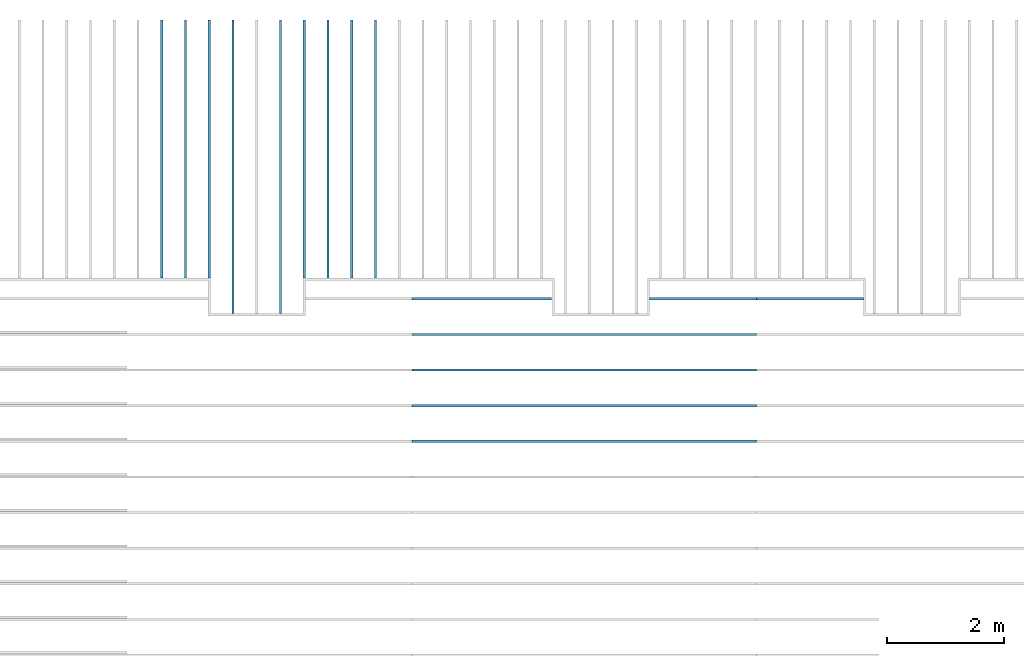
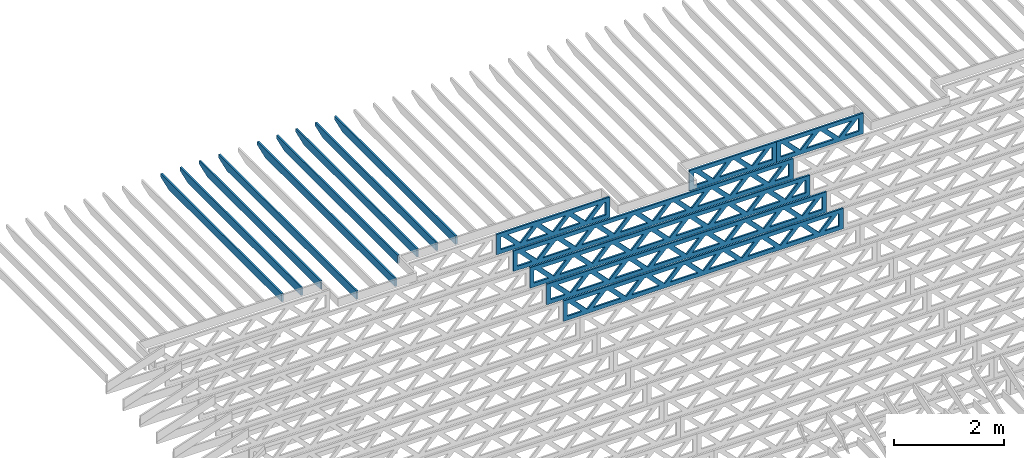
# One storey, part 5 of 17: 16 beams, 3 elements without a shape of their own.
"""IFC4 building model written with IfcOpenShell, lengths in feet."""

from ifc_helpers import new_model, entity, si_unit, converted_unit, derived_unit, direction, frame, frame_2d, origin, origin_2d_with_axis, place, context, subcontext, project, spatial, rectangle, extrude, clip, halfspace, source, transform, mapped, material, material_profile, profile_set, profile_usage, type_object, type_shapes, element, aggregate, save


model = new_model("IFC4")

# Units and contexts
model_context = context("Model", 3, precision=0.0001, world=origin(), true_north=direction((6.12303176911189e-17, 1.0)))
body_context = subcontext(model_context, "Body", "Model", "MODEL_VIEW")
ifc_project = project(units=[converted_unit("LENGTHUNIT", "FOOT", entity("IfcRatioMeasure", 0.3048), si_unit("LENGTHUNIT", "METRE"), dimensions=[1, 0, 0, 0, 0, 0, 0]), converted_unit("AREAUNIT", "SQUARE FOOT", entity("IfcRatioMeasure", 0.09290304), si_unit("AREAUNIT", "SQUARE_METRE"), dimensions=[2, 0, 0, 0, 0, 0, 0]), converted_unit("VOLUMEUNIT", "CUBIC FOOT", entity("IfcRatioMeasure", 0.028316846592), si_unit("VOLUMEUNIT", "CUBIC_METRE"), dimensions=[3, 0, 0, 0, 0, 0, 0]), converted_unit("PLANEANGLEUNIT", "DEGREE", entity("IfcRatioMeasure", 0.0174532925199433), si_unit("PLANEANGLEUNIT", "RADIAN"), dimensions=[0, 0, 0, 0, 0, 0, 0]), si_unit("MASSUNIT", "GRAM", prefix="KILO"), derived_unit("MASSDENSITYUNIT", [(si_unit("MASSUNIT", "GRAM", prefix="KILO"), 1), (si_unit("LENGTHUNIT", "METRE"), -3)]), derived_unit("MOMENTOFINERTIAUNIT", [(si_unit("LENGTHUNIT", "METRE"), 4)]), si_unit("TIMEUNIT", "SECOND"), si_unit("FREQUENCYUNIT", "HERTZ"), si_unit("THERMODYNAMICTEMPERATUREUNIT", "DEGREE_CELSIUS"), derived_unit("THERMALTRANSMITTANCEUNIT", [(si_unit("MASSUNIT", "GRAM", prefix="KILO"), 1), (si_unit("THERMODYNAMICTEMPERATUREUNIT", "KELVIN"), -1), (si_unit("TIMEUNIT", "SECOND"), -3)]), derived_unit("VOLUMETRICFLOWRATEUNIT", [(si_unit("LENGTHUNIT", "METRE"), 3), (si_unit("TIMEUNIT", "SECOND"), -1)]), si_unit("ELECTRICCURRENTUNIT", "AMPERE"), si_unit("ELECTRICVOLTAGEUNIT", "VOLT"), si_unit("POWERUNIT", "WATT"), si_unit("FORCEUNIT", "NEWTON"), si_unit("ILLUMINANCEUNIT", "LUX"), si_unit("LUMINOUSFLUXUNIT", "LUMEN"), si_unit("LUMINOUSINTENSITYUNIT", "CANDELA"), derived_unit("USERDEFINED", [(si_unit("MASSUNIT", "GRAM", prefix="KILO"), -1), (si_unit("LENGTHUNIT", "METRE"), -2), (si_unit("TIMEUNIT", "SECOND"), 3), (si_unit("LUMINOUSFLUXUNIT", "LUMEN"), 1)]), derived_unit("LINEARVELOCITYUNIT", [(si_unit("LENGTHUNIT", "METRE"), 1), (si_unit("TIMEUNIT", "SECOND"), -1)]), si_unit("PRESSUREUNIT", "PASCAL"), derived_unit("USERDEFINED", [(si_unit("LENGTHUNIT", "METRE"), -2), (si_unit("MASSUNIT", "GRAM", prefix="KILO"), 1), (si_unit("TIMEUNIT", "SECOND"), -2)]), derived_unit("LINEARFORCEUNIT", [(si_unit("MASSUNIT", "GRAM", prefix="KILO"), 1), (si_unit("LENGTHUNIT", "METRE"), 1), (si_unit("TIMEUNIT", "SECOND"), -2), (si_unit("LENGTHUNIT", "METRE"), -1)]), derived_unit("PLANARFORCEUNIT", [(si_unit("MASSUNIT", "GRAM", prefix="KILO"), 1), (si_unit("LENGTHUNIT", "METRE"), 1), (si_unit("TIMEUNIT", "SECOND"), -2), (si_unit("LENGTHUNIT", "METRE"), -2)])], contexts=[model_context])

# Site, building, storey
site_placement = place(None, origin())
site = spatial("IfcSite", under=ifc_project, at=site_placement, CompositionType="ELEMENT")
building_placement = place(site_placement, origin())
building = spatial("IfcBuilding", under=site, at=building_placement, CompositionType="ELEMENT")
storey_placement = place(building_placement, frame((0.0, 0.0, 30.4375000000082)))
storey = spatial("IfcBuildingStorey", under=building, at=storey_placement, Name="ROOF", CompositionType="ELEMENT", Elevation=30.4375000000082)

# Assembly, beams
assembly_1_placement = place(storey_placement, origin())
assembly_1 = element("IfcElementAssembly", 1, at=assembly_1_placement, inside=storey, Name="Structural Beam System:Structural Framing System", ObjectType="Structural Beam System:Structural Framing System", AssemblyPlace="NOTDEFINED", PredefinedType="BEAM_GRID")
ifc_material_1 = material(Name="WOOD TRUSS", Category="Materials")
ifc_material_profile_1 = material_profile(ifc_material_1, rectangle(XDim=1.73473973950632, YDim=0.125, at=origin_2d_with_axis()))
ifc_material_profile_2 = material_profile(ifc_material_1, rectangle(XDim=1.73473973950633, YDim=0.125, at=frame_2d((-1.11022302462516e-16, 0.0), x_axis=(1.0, 0.0))))
ifc_material_profile_3 = material_profile(ifc_material_1, rectangle(XDim=1.73473973950632, YDim=0.125, at=origin_2d_with_axis()))
ifc_material_profile_4 = material_profile(ifc_material_1, rectangle(XDim=1.73473973950633, YDim=0.125, at=origin_2d_with_axis()))
ifc_material_profile_5 = material_profile(ifc_material_1, rectangle(XDim=1.73473973950632, YDim=0.125, at=frame_2d((-5.55111512312578e-17, 0.0), x_axis=(1.0, 0.0))))
ifc_material_profile_6 = material_profile(ifc_material_1, rectangle(XDim=1.73473973950633, YDim=0.125, at=frame_2d((-2.77555756156289e-16, 0.0), x_axis=(1.0, 0.0))))
ifc_material_profile_7 = material_profile(ifc_material_1, rectangle(XDim=1.73473973950632, YDim=0.125, at=frame_2d((-4.9960036108132e-16, 0.0), x_axis=(1.0, 0.0))))
ifc_material_profile_8 = material_profile(ifc_material_1, rectangle(XDim=1.73473973950633, YDim=0.125, at=frame_2d((4.44089209850063e-16, 0.0), x_axis=(1.0, 0.0))))
ifc_material_profile_9 = material_profile(ifc_material_1, rectangle(XDim=1.73473973950632, YDim=0.125, at=origin_2d_with_axis()))
ifc_material_profile_10 = material_profile(ifc_material_1, rectangle(XDim=1.73473973950633, YDim=0.125, at=frame_2d((-4.9960036108132e-16, 0.0), x_axis=(1.0, 0.0))))
ifc_material_profile_11 = material_profile(ifc_material_1, rectangle(XDim=0.291666666666664, YDim=0.125, at=frame_2d((-2.77555756156289e-17, 0.0), x_axis=(1.0, 0.0))))
ifc_material_profile_12 = material_profile(ifc_material_1, rectangle(XDim=0.291666666666628, YDim=0.124999999999995, at=frame_2d((-5.55111512312578e-17, 0.0), x_axis=(1.0, 0.0))))
ifc_material_profile_13 = material_profile(ifc_material_1, rectangle(XDim=0.916666666666666, YDim=0.125000000000003, at=frame_2d((-2.77555756156289e-17, 0.0), x_axis=(1.0, 0.0))))
ifc_material_profile_14 = material_profile(ifc_material_1, rectangle(XDim=0.916666666666651, YDim=0.125, at=frame_2d((-2.77555756156289e-17, 0.0), x_axis=(1.0, 0.0))))
ifc_profile_set_1 = profile_set([ifc_material_profile_1, ifc_material_profile_2, ifc_material_profile_3, ifc_material_profile_4, ifc_material_profile_5, ifc_material_profile_6, ifc_material_profile_7, ifc_material_profile_8, ifc_material_profile_9, ifc_material_profile_10, ifc_material_profile_11, ifc_material_profile_12, ifc_material_profile_13, ifc_material_profile_14])
ifc_profile_usage_1 = profile_usage(ifc_profile_set_1, cardinal=8)
beam_type_1 = type_object("IfcBeamType", PredefinedType="BEAM", material=ifc_profile_set_1)
shared_shape_1 = source(origin(), body_context, "Body", "SweptSolid", [
    extrude(rectangle(XDim=1.73473973950632, YDim=0.125, at=origin_2d_with_axis()), frame((0.520059930714934, 0.0, 0.101118361020562), z_axis=(0.720569184836762, 0.0, -0.693383046997606), x_axis=(0.693383046997606, 0.0, 0.720569184836762)), (0.0, 0.0, 1.0), 0.291666666666667),
    extrude(rectangle(XDim=1.73473973950633, YDim=0.125, at=origin_2d_with_axis()), frame((-0.730225942958336, 0.0, -0.101118361020407), z_axis=(0.720569184836758, 0.0, 0.69338304699761), x_axis=(0.69338304699761, 0.0, -0.720569184836758)), (0.0, 0.0, 1.0), 0.291666666666666),
    extrude(rectangle(XDim=1.73473973950632, YDim=0.125, at=origin_2d_with_axis()), frame((2.77005983191593, 0.0, 0.101118361020514), z_axis=(0.720569184836762, 0.0, -0.693383046997606), x_axis=(0.693383046997606, 0.0, 0.720569184836762)), (0.0, 0.0, 1.0), 0.291666666666667),
    extrude(rectangle(XDim=1.73473973950633, YDim=0.125, at=frame_2d((-1.11022302462516e-16, 0.0), x_axis=(1.0, 0.0))), frame((1.51977395824266, 0.0, -0.101118361020455), z_axis=(0.720569184836758, 0.0, 0.69338304699761), x_axis=(0.69338304699761, 0.0, -0.720569184836758)), (0.0, 0.0, 1.0), 0.291666666666666),
    extrude(rectangle(XDim=1.73473973950632, YDim=0.125, at=frame_2d((-5.55111512312578e-17, 0.0), x_axis=(1.0, 0.0))), frame((-1.72993997048606, 0.0, 0.101118361020555), z_axis=(0.720569184836762, 0.0, -0.693383046997606), x_axis=(0.693383046997606, 0.0, 0.720569184836762)), (0.0, 0.0, 1.0), 0.291666666666667),
    extrude(rectangle(XDim=1.73473973950633, YDim=0.125, at=frame_2d((-2.77555756156289e-16, 0.0), x_axis=(1.0, 0.0))), frame((-2.98022584415933, 0.0, -0.101118361020414), z_axis=(0.720569184836758, 0.0, 0.69338304699761), x_axis=(0.69338304699761, 0.0, -0.720569184836758)), (0.0, 0.0, 1.0), 0.291666666666666),
    extrude(rectangle(XDim=0.291666666666664, YDim=0.125, at=frame_2d((-2.77555756156289e-17, 0.0), x_axis=(1.0, 0.0))), frame((-3.91666656786758, 0.0, 0.604166666666611), z_axis=(1.0, 0.0, 0.0), x_axis=(0.0, 0.0, -1.0)), (0.0, 0.0, 1.0), 7.83333313573516),
    extrude(rectangle(XDim=0.291666666666628, YDim=0.124999999999995, at=frame_2d((-5.55111512312578e-17, 0.0), x_axis=(1.0, 0.0))), frame((-3.91666656786737, 0.0, -0.604166666666693), z_axis=(1.0, 0.0, 0.0), x_axis=(0.0, 0.0, -1.0)), (0.0, 0.0, 1.0), 7.83333313573495),
    extrude(rectangle(XDim=0.916666666666666, YDim=0.125000000000003, at=frame_2d((-2.77555756156289e-17, 0.0), x_axis=(1.0, 0.0))), frame((3.62499990120089, 0.0, 0.0), z_axis=(1.0, 0.0, 0.0), x_axis=(0.0, 0.0, -1.0)), (0.0, 0.0, 1.0), 0.291666666666687),
    extrude(rectangle(XDim=0.916666666666651, YDim=0.125, at=frame_2d((-2.77555756156289e-17, 0.0), x_axis=(1.0, 0.0))), frame((-3.91666656786758, 0.0, 0.0), z_axis=(1.0, 0.0, 0.0), x_axis=(0.0, 0.0, -1.0)), (0.0, 0.0, 1.0), 0.291666666666687),
])
type_shapes(beam_type_1, [shared_shape_1])
beam_1_placement = place(assembly_1_placement, frame((-237.821493917626, 957.861934882651, 0.749999999991608)))
beam_1 = element("IfcBeam", 2, at=beam_1_placement, type_object=beam_type_1, material=ifc_profile_usage_1, PredefinedType="BEAM", context=body_context, shape_type="MappedRepresentation", body=[
    mapped(shared_shape_1, transform((0.0, 0.0, 0.0), scale=1.0)),
])
ifc_profile_usage_2 = profile_usage(ifc_profile_set_1, cardinal=8)
beam_type_2 = type_object("IfcBeamType", PredefinedType="BEAM", material=ifc_profile_set_1)
shared_shape_2 = source(origin(), body_context, "Body", "SweptSolid", [
    extrude(rectangle(XDim=1.73473973950632, YDim=0.125, at=frame_2d((5.55111512312578e-17, 0.0), x_axis=(1.0, 0.0))), frame((1.8533931188195, 0.0, 0.101118361020515), z_axis=(0.720569184836762, 0.0, -0.693383046997606), x_axis=(0.693383046997606, 0.0, 0.720569184836762)), (0.0, 0.0, 1.0), 0.291666666666667),
    extrude(rectangle(XDim=1.73473973950633, YDim=0.125, at=frame_2d((-1.11022302462516e-16, 0.0), x_axis=(1.0, 0.0))), frame((0.603107245146231, 0.0, -0.101118361020454), z_axis=(0.720569184836758, 0.0, 0.69338304699761), x_axis=(0.69338304699761, 0.0, -0.720569184836758)), (0.0, 0.0, 1.0), 0.291666666666667),
    extrude(rectangle(XDim=1.73473973950632, YDim=0.125, at=frame_2d((-5.55111512312578e-17, 0.0), x_axis=(1.0, 0.0))), frame((-0.81327325738963, 0.0, 0.101118361020554), z_axis=(0.720569184836762, 0.0, -0.693383046997606), x_axis=(0.693383046997606, 0.0, 0.720569184836762)), (0.0, 0.0, 1.0), 0.291666666666667),
    extrude(rectangle(XDim=1.73473973950633, YDim=0.125, at=frame_2d((-1.66533453693773e-16, 0.0), x_axis=(1.0, 0.0))), frame((-2.0635591310629, 0.0, -0.101118361020415), z_axis=(0.720569184836758, 0.0, 0.69338304699761), x_axis=(0.69338304699761, 0.0, -0.720569184836758)), (0.0, 0.0, 1.0), 0.291666666666666),
    extrude(rectangle(XDim=0.291666666666664, YDim=0.125, at=frame_2d((-2.77555756156289e-17, 0.0), x_axis=(1.0, 0.0))), frame((-2.99999985477115, 0.0, 0.604166666666611), z_axis=(1.0, 0.0, 0.0), x_axis=(0.0, 0.0, -1.0)), (0.0, 0.0, 1.0), 5.99999970954229),
    extrude(rectangle(XDim=0.291666666666628, YDim=0.124999999999995, at=frame_2d((-5.55111512312578e-17, 0.0), x_axis=(1.0, 0.0))), frame((-2.99999985477093, 0.0, -0.604166666666693), z_axis=(1.0, 0.0, 0.0), x_axis=(0.0, 0.0, -1.0)), (0.0, 0.0, 1.0), 5.99999970954208),
    extrude(rectangle(XDim=0.916666666666666, YDim=0.125000000000003, at=frame_2d((-2.77555756156289e-17, 0.0), x_axis=(1.0, 0.0))), frame((2.70833318810446, 0.0, 0.0), z_axis=(1.0, 0.0, 0.0), x_axis=(0.0, 0.0, -1.0)), (0.0, 0.0, 1.0), 0.291666666666687),
    extrude(rectangle(XDim=0.916666666666651, YDim=0.125, at=frame_2d((-2.77555756156289e-17, 0.0), x_axis=(1.0, 0.0))), frame((-2.99999985477115, 0.0, 0.0), z_axis=(1.0, 0.0, 0.0), x_axis=(0.0, 0.0, -1.0)), (0.0, 0.0, 1.0), 0.291666666666687),
])
type_shapes(beam_type_2, [shared_shape_2])
beam_2_placement = place(assembly_1_placement, frame((-225.404827006933, 957.861934882651, 0.749999999991608)))
beam_2 = element("IfcBeam", 3, at=beam_2_placement, type_object=beam_type_2, material=ifc_profile_usage_2, PredefinedType="BEAM", context=body_context, shape_type="MappedRepresentation", body=[
    mapped(shared_shape_2, transform((0.0, 0.0, 0.0), scale=1.0)),
])
ifc_profile_usage_3 = profile_usage(ifc_profile_set_1, cardinal=8)
beam_type_3 = type_object("IfcBeamType", PredefinedType="BEAM", material=ifc_profile_set_1)
shared_shape_3 = source(origin(), body_context, "Body", "SweptSolid", [
    extrude(rectangle(XDim=1.73473973950632, YDim=0.125, at=frame_2d((-5.55111512312578e-16, 0.0), x_axis=(1.0, 0.0))), frame((5.85339326404794, 0.0, 0.101118361020562), z_axis=(0.720569184836762, 0.0, -0.693383046997606), x_axis=(0.693383046997606, 0.0, 0.720569184836762)), (0.0, 0.0, 1.0), 0.291666666666667),
    extrude(rectangle(XDim=1.73473973950633, YDim=0.125, at=frame_2d((-4.9960036108132e-16, 0.0), x_axis=(1.0, 0.0))), frame((4.60310739037467, 0.0, -0.101118361020407), z_axis=(0.720569184836758, 0.0, 0.69338304699761), x_axis=(0.69338304699761, 0.0, -0.720569184836758)), (0.0, 0.0, 1.0), 0.291666666666667),
    extrude(rectangle(XDim=1.73473973950632, YDim=0.125, at=frame_2d((3.33066907387547e-16, 0.0), x_axis=(1.0, 0.0))), frame((3.18672659738144, 0.0, 0.101118361020562), z_axis=(0.720569184836762, 0.0, -0.693383046997606), x_axis=(0.693383046997606, 0.0, 0.720569184836762)), (0.0, 0.0, 1.0), 0.291666666666667),
    extrude(rectangle(XDim=1.73473973950633, YDim=0.125, at=frame_2d((-1.11022302462516e-16, 0.0), x_axis=(1.0, 0.0))), frame((1.93644072370817, 0.0, -0.101118361020407), z_axis=(0.720569184836758, 0.0, 0.69338304699761), x_axis=(0.69338304699761, 0.0, -0.720569184836758)), (0.0, 0.0, 1.0), 0.291666666666666),
    extrude(rectangle(XDim=1.73473973950632, YDim=0.125, at=frame_2d((5.55111512312578e-17, 0.0), x_axis=(1.0, 0.0))), frame((0.520059930714937, 0.0, 0.101118361020562), z_axis=(0.720569184836762, 0.0, -0.693383046997606), x_axis=(0.693383046997606, 0.0, 0.720569184836762)), (0.0, 0.0, 1.0), 0.291666666666667),
    extrude(rectangle(XDim=1.73473973950633, YDim=0.125, at=origin_2d_with_axis()), frame((-0.730225942958334, 0.0, -0.101118361020407), z_axis=(0.720569184836758, 0.0, 0.69338304699761), x_axis=(0.69338304699761, 0.0, -0.720569184836758)), (0.0, 0.0, 1.0), 0.291666666666666),
    extrude(rectangle(XDim=1.73473973950632, YDim=0.125, at=frame_2d((-5.55111512312578e-17, 0.0), x_axis=(1.0, 0.0))), frame((-2.14660673595157, 0.0, 0.101118361020562), z_axis=(0.720569184836762, 0.0, -0.693383046997606), x_axis=(0.693383046997606, 0.0, 0.720569184836762)), (0.0, 0.0, 1.0), 0.291666666666667),
    extrude(rectangle(XDim=1.73473973950633, YDim=0.125, at=frame_2d((-2.77555756156289e-16, 0.0), x_axis=(1.0, 0.0))), frame((-3.39689260962484, 0.0, -0.101118361020407), z_axis=(0.720569184836758, 0.0, 0.69338304699761), x_axis=(0.69338304699761, 0.0, -0.720569184836758)), (0.0, 0.0, 1.0), 0.291666666666666),
    extrude(rectangle(XDim=1.73473973950632, YDim=0.125, at=origin_2d_with_axis()), frame((-4.81327340261807, 0.0, 0.101118361020562), z_axis=(0.720569184836762, 0.0, -0.693383046997606), x_axis=(0.693383046997606, 0.0, 0.720569184836762)), (0.0, 0.0, 1.0), 0.291666666666667),
    extrude(rectangle(XDim=1.73473973950633, YDim=0.125, at=frame_2d((-4.9960036108132e-16, 0.0), x_axis=(1.0, 0.0))), frame((-6.06355927629134, 0.0, -0.101118361020407), z_axis=(0.720569184836758, 0.0, 0.69338304699761), x_axis=(0.69338304699761, 0.0, -0.720569184836758)), (0.0, 0.0, 1.0), 0.291666666666667),
    extrude(rectangle(XDim=1.73473973950632, YDim=0.125, at=frame_2d((-1.0547118733939e-15, 0.0), x_axis=(1.0, 0.0))), frame((8.52005993071445, 0.0, 0.101118361020506), z_axis=(0.720569184836761, 0.0, -0.693383046997607), x_axis=(0.693383046997607, 0.0, 0.720569184836761)), (0.0, 0.0, 1.0), 0.291666666666667),
    extrude(rectangle(XDim=1.73473973950633, YDim=0.125, at=origin_2d_with_axis()), frame((7.26977405704118, 0.0, -0.101118361020463), z_axis=(0.720569184836758, 0.0, 0.69338304699761), x_axis=(0.69338304699761, 0.0, -0.720569184836758)), (0.0, 0.0, 1.0), 0.291666666666667),
    extrude(rectangle(XDim=1.73473973950632, YDim=0.125, at=frame_2d((4.44089209850063e-16, 0.0), x_axis=(1.0, 0.0))), frame((-7.47994006928457, 0.0, 0.101118361020561), z_axis=(0.720569184836762, 0.0, -0.693383046997606), x_axis=(0.693383046997606, 0.0, 0.720569184836762)), (0.0, 0.0, 1.0), 0.291666666666666),
    extrude(rectangle(XDim=1.73473973950633, YDim=0.125, at=origin_2d_with_axis()), frame((-8.73022594295784, 0.0, -0.101118361020408), z_axis=(0.720569184836758, 0.0, 0.69338304699761), x_axis=(0.69338304699761, 0.0, -0.720569184836758)), (0.0, 0.0, 1.0), 0.291666666666666),
    extrude(rectangle(XDim=0.291666666666664, YDim=0.125, at=frame_2d((-2.77555756156289e-17, 0.0), x_axis=(1.0, 0.0))), frame((-9.66666666666609, 0.0, 0.604166666666611), z_axis=(1.0, 0.0, 0.0), x_axis=(0.0, 0.0, -1.0)), (0.0, 0.0, 1.0), 19.3333333333322),
    extrude(rectangle(XDim=0.291666666666628, YDim=0.124999999999995, at=frame_2d((-5.55111512312578e-17, 0.0), x_axis=(1.0, 0.0))), frame((-9.66666666666588, 0.0, -0.604166666666693), z_axis=(1.0, 0.0, 0.0), x_axis=(0.0, 0.0, -1.0)), (0.0, 0.0, 1.0), 19.333333333332),
    extrude(rectangle(XDim=0.916666666666666, YDim=0.125000000000003, at=frame_2d((-2.77555756156289e-17, 0.0), x_axis=(1.0, 0.0))), frame((9.3749999999994, 0.0, 0.0), z_axis=(1.0, 0.0, 0.0), x_axis=(0.0, 0.0, -1.0)), (0.0, 0.0, 1.0), 0.291666666666687),
    extrude(rectangle(XDim=0.916666666666651, YDim=0.125, at=frame_2d((-2.77555756156289e-17, 0.0), x_axis=(1.0, 0.0))), frame((-9.66666666666609, 0.0, 0.0), z_axis=(1.0, 0.0, 0.0), x_axis=(0.0, 0.0, -1.0)), (0.0, 0.0, 1.0), 0.291666666666687),
])
type_shapes(beam_type_3, [shared_shape_3])
beam_3_placement = place(assembly_1_placement, frame((-232.071493818828, 955.861934882651, 0.749999999991608)))
beam_3 = element("IfcBeam", 4, at=beam_3_placement, type_object=beam_type_3, material=ifc_profile_usage_3, PredefinedType="BEAM", context=body_context, shape_type="MappedRepresentation", body=[
    mapped(shared_shape_3, transform((0.0, 0.0, 0.0), scale=1.0)),
])
ifc_profile_usage_4 = profile_usage(ifc_profile_set_1, cardinal=8)
beam_4_placement = place(assembly_1_placement, frame((-232.071493818828, 953.861934882651, 0.749999999991616)))
beam_4 = element("IfcBeam", 5, at=beam_4_placement, type_object=beam_type_3, material=ifc_profile_usage_4, PredefinedType="BEAM", context=body_context, shape_type="MappedRepresentation", body=[
    mapped(shared_shape_3, transform((0.0, 0.0, 0.0), scale=1.0)),
])
ifc_profile_usage_5 = profile_usage(ifc_profile_set_1, cardinal=8)
beam_5_placement = place(assembly_1_placement, frame((-232.071493818828, 951.861934882651, 0.749999999991623)))
beam_5 = element("IfcBeam", 6, at=beam_5_placement, type_object=beam_type_3, material=ifc_profile_usage_5, PredefinedType="BEAM", context=body_context, shape_type="MappedRepresentation", body=[
    mapped(shared_shape_3, transform((0.0, 0.0, 0.0), scale=1.0)),
])
ifc_profile_usage_6 = profile_usage(ifc_profile_set_1, cardinal=8)
beam_6_placement = place(assembly_1_placement, frame((-232.071493818828, 949.861934882651, 0.749999999991623)))
beam_6 = element("IfcBeam", 7, at=beam_6_placement, type_object=beam_type_3, material=ifc_profile_usage_6, PredefinedType="BEAM", context=body_context, shape_type="MappedRepresentation", body=[
    mapped(shared_shape_3, transform((0.0, 0.0, 0.0), scale=1.0)),
])
aggregate(assembly_1, [beam_1, beam_2, beam_3, beam_4, beam_5, beam_6])

# Assembly, beam
assembly_2_placement = place(storey_placement, origin())
assembly_2 = element("IfcElementAssembly", 8, at=assembly_2_placement, inside=storey, Name="Structural Beam System:Structural Framing System", ObjectType="Structural Beam System:Structural Framing System", AssemblyPlace="NOTDEFINED", PredefinedType="BEAM_GRID")
ifc_profile_usage_7 = profile_usage(ifc_profile_set_1, cardinal=8)
beam_type_4 = type_object("IfcBeamType", PredefinedType="BEAM", material=ifc_profile_set_1)
shared_shape_4 = source(origin(), body_context, "Body", "SweptSolid", [
    extrude(rectangle(XDim=1.73473973950632, YDim=0.125, at=frame_2d((5.55111512312578e-17, 0.0), x_axis=(1.0, 0.0))), frame((1.85339310373314, 0.0, 0.101118361020515), z_axis=(0.720569184836762, 0.0, -0.693383046997606), x_axis=(0.693383046997606, 0.0, 0.720569184836762)), (0.0, 0.0, 1.0), 0.291666666666667),
    extrude(rectangle(XDim=1.73473973950633, YDim=0.125, at=frame_2d((-1.11022302462516e-16, 0.0), x_axis=(1.0, 0.0))), frame((0.603107230059874, 0.0, -0.101118361020454), z_axis=(0.720569184836758, 0.0, 0.69338304699761), x_axis=(0.69338304699761, 0.0, -0.720569184836758)), (0.0, 0.0, 1.0), 0.291666666666667),
    extrude(rectangle(XDim=1.73473973950632, YDim=0.125, at=frame_2d((-5.55111512312578e-17, 0.0), x_axis=(1.0, 0.0))), frame((-0.813273242303273, 0.0, 0.101118361020554), z_axis=(0.720569184836762, 0.0, -0.693383046997606), x_axis=(0.693383046997606, 0.0, 0.720569184836762)), (0.0, 0.0, 1.0), 0.291666666666667),
    extrude(rectangle(XDim=1.73473973950633, YDim=0.125, at=frame_2d((-1.66533453693773e-16, 0.0), x_axis=(1.0, 0.0))), frame((-2.06355911597654, 0.0, -0.101118361020415), z_axis=(0.720569184836758, 0.0, 0.69338304699761), x_axis=(0.69338304699761, 0.0, -0.720569184836758)), (0.0, 0.0, 1.0), 0.291666666666666),
    extrude(rectangle(XDim=0.291666666666664, YDim=0.125, at=frame_2d((-2.77555756156289e-17, 0.0), x_axis=(1.0, 0.0))), frame((-2.99999983968479, 0.0, 0.604166666666611), z_axis=(1.0, 0.0, 0.0), x_axis=(0.0, 0.0, -1.0)), (0.0, 0.0, 1.0), 5.99999967936958),
    extrude(rectangle(XDim=0.291666666666628, YDim=0.124999999999995, at=frame_2d((-5.55111512312578e-17, 0.0), x_axis=(1.0, 0.0))), frame((-2.99999983968458, 0.0, -0.604166666666693), z_axis=(1.0, 0.0, 0.0), x_axis=(0.0, 0.0, -1.0)), (0.0, 0.0, 1.0), 5.99999967936937),
    extrude(rectangle(XDim=0.916666666666666, YDim=0.125000000000003, at=frame_2d((-2.77555756156289e-17, 0.0), x_axis=(1.0, 0.0))), frame((2.7083331730181, 0.0, 0.0), z_axis=(1.0, 0.0, 0.0), x_axis=(0.0, 0.0, -1.0)), (0.0, 0.0, 1.0), 0.291666666666687),
    extrude(rectangle(XDim=0.916666666666651, YDim=0.125, at=frame_2d((-2.77555756156289e-17, 0.0), x_axis=(1.0, 0.0))), frame((-2.99999983968479, 0.0, 0.0), z_axis=(1.0, 0.0, 0.0), x_axis=(0.0, 0.0, -1.0)), (0.0, 0.0, 1.0), 0.291666666666687),
])
type_shapes(beam_type_4, [shared_shape_4])
beam_7_placement = place(assembly_2_placement, frame((-219.404827312475, 957.861934882651, 0.749999999991601), z_axis=(0.0, 0.0, 1.0), x_axis=(-1.0, 0.0, 0.0)))
beam_7 = element("IfcBeam", 9, at=beam_7_placement, type_object=beam_type_4, material=ifc_profile_usage_7, PredefinedType="BEAM", context=body_context, shape_type="MappedRepresentation", body=[
    mapped(shared_shape_4, transform((0.0, 0.0, 0.0), scale=1.0)),
])
aggregate(assembly_2, [beam_7])

# Assembly, beams
assembly_3_placement = place(storey_placement, origin())
assembly_3 = element("IfcElementAssembly", 10, at=assembly_3_placement, inside=storey, Name="Structural Beam System:Structural Framing System", ObjectType="Structural Beam System:Structural Framing System", AssemblyPlace="NOTDEFINED", PredefinedType="BEAM_GRID")
ifc_material_2 = material(Name="2X ROOF JOISTS - EXT. STAIN-1 - SEE LIFE SAFETY", Category="Materials")
ifc_material_profile_15 = material_profile(ifc_material_2, rectangle(XDim=0.604166666666667, YDim=0.125000000000011, at=frame_2d((0.0, 0.0), x_axis=(0.0, 1.0))))
ifc_profile_set_2 = profile_set([ifc_material_profile_15])
ifc_profile_usage_8 = profile_usage(ifc_profile_set_2, cardinal=8)
beam_type_5 = type_object("IfcBeamType", PredefinedType="BEAM", material=ifc_profile_set_2)
shared_shape_5 = source(origin(), body_context, "Body", "Clipping", [
    clip(extrude(rectangle(XDim=0.604166666666667, YDim=0.125000000000011, at=frame_2d((0.0, 0.0), x_axis=(0.0, 1.0))), frame((-8.24296473987818, 0.0, 0.0), z_axis=(1.0, 0.0, 0.0), x_axis=(0.0, 1.0, 0.0)), (0.0, 0.0, 1.0), 16.4859294797564), halfspace(frame((-7.26989982048795, -0.0625000000000026, -0.30208333333334), z_axis=(-0.34202014332567, 0.0, -0.939692620785908), x_axis=(0.0, 1.0, 0.0)), False)),
])
type_shapes(beam_type_5, [shared_shape_5])
beam_8_placement = place(assembly_3_placement, frame((-249.133993818795, 965.271566289195, 1.07291666665834), z_axis=(0.0, 0.0, 1.0), x_axis=(0.0, -1.0, 0.0)))
beam_8 = element("IfcBeam", 11, at=beam_8_placement, type_object=beam_type_5, material=ifc_profile_usage_8, PredefinedType="BEAM", context=body_context, shape_type="MappedRepresentation", body=[
    mapped(shared_shape_5, transform((0.0, 0.0, 0.0), scale=1.0)),
])
ifc_profile_usage_9 = profile_usage(ifc_profile_set_2, cardinal=8)
beam_9_placement = place(assembly_3_placement, frame((-251.800660485462, 965.271566289195, 1.07291666665834), z_axis=(0.0, 0.0, 1.0), x_axis=(0.0, -1.0, 0.0)))
beam_9 = element("IfcBeam", 12, at=beam_9_placement, type_object=beam_type_5, material=ifc_profile_usage_9, PredefinedType="BEAM", context=body_context, shape_type="MappedRepresentation", body=[
    mapped(shared_shape_5, transform((0.0, 0.0, 0.0), scale=1.0)),
])
ifc_profile_usage_10 = profile_usage(ifc_profile_set_2, cardinal=8)
beam_type_6 = type_object("IfcBeamType", PredefinedType="BEAM", material=ifc_profile_set_2)
shared_shape_6 = source(origin(), body_context, "Body", "Clipping", [
    clip(extrude(rectangle(XDim=0.604166666666667, YDim=0.125000000000011, at=frame_2d((0.0, 0.0), x_axis=(0.0, 1.0))), frame((-7.24296367016814, 0.0, 0.0), z_axis=(1.0, 0.0, 0.0), x_axis=(0.0, 1.0, 0.0)), (0.0, 0.0, 1.0), 14.4859273403363), halfspace(frame((-6.26989875077791, -0.0625000000000026, -0.30208333333334), z_axis=(-0.34202014332567, 0.0, -0.939692620785908), x_axis=(0.0, 1.0, 0.0)), False)),
])
type_shapes(beam_type_6, [shared_shape_6])
beam_10_placement = place(assembly_3_placement, frame((-245.133993818795, 966.271567356882, 1.07291666665833), z_axis=(0.0, 0.0, 1.0), x_axis=(0.0, -1.0, 0.0)))
beam_10 = element("IfcBeam", 13, at=beam_10_placement, type_object=beam_type_6, material=ifc_profile_usage_10, PredefinedType="BEAM", context=body_context, shape_type="MappedRepresentation", body=[
    mapped(shared_shape_6, transform((0.0, 0.0, 0.0), scale=1.0)),
])
ifc_profile_usage_11 = profile_usage(ifc_profile_set_2, cardinal=8)
beam_type_7 = type_object("IfcBeamType", PredefinedType="BEAM", material=ifc_profile_set_2)
shared_shape_7 = source(origin(), body_context, "Body", "Clipping", [
    clip(extrude(rectangle(XDim=0.604166666666667, YDim=0.125000000000011, at=frame_2d((0.0, 0.0), x_axis=(0.0, 1.0))), frame((-7.24296351885744, 0.0, 0.0), z_axis=(1.0, 0.0, 0.0), x_axis=(0.0, 1.0, 0.0)), (0.0, 0.0, 1.0), 14.4859270377149), halfspace(frame((-6.26989859946721, -0.0625000000000026, -0.30208333333334), z_axis=(-0.34202014332567, 0.0, -0.939692620785908), x_axis=(0.0, 1.0, 0.0)), False)),
])
type_shapes(beam_type_7, [shared_shape_7])
beam_11_placement = place(assembly_3_placement, frame((-246.467327152128, 966.271567524383, 1.07291666665834), z_axis=(0.0, 0.0, 1.0), x_axis=(0.0, -1.0, 0.0)))
beam_11 = element("IfcBeam", 14, at=beam_11_placement, type_object=beam_type_7, material=ifc_profile_usage_11, PredefinedType="BEAM", context=body_context, shape_type="MappedRepresentation", body=[
    mapped(shared_shape_7, transform((0.0, 0.0, 0.0), scale=1.0)),
])
ifc_profile_usage_12 = profile_usage(ifc_profile_set_2, cardinal=8)
beam_type_8 = type_object("IfcBeamType", PredefinedType="BEAM", material=ifc_profile_set_2)
shared_shape_8 = source(origin(), body_context, "Body", "Clipping", [
    clip(extrude(rectangle(XDim=0.604166666666667, YDim=0.125000000000011, at=frame_2d((0.0, 0.0), x_axis=(0.0, 1.0))), frame((-7.24296383969306, 0.0, 0.0), z_axis=(1.0, 0.0, 0.0), x_axis=(0.0, 1.0, 0.0)), (0.0, 0.0, 1.0), 14.4859276793861), halfspace(frame((-6.26989892030283, -0.0625000000000026, -0.30208333333334), z_axis=(-0.34202014332567, 0.0, -0.939692620785908), x_axis=(0.0, 1.0, 0.0)), False)),
])
type_shapes(beam_type_8, [shared_shape_8])
beam_12_placement = place(assembly_3_placement, frame((-243.800660485462, 966.27156718938, 1.07291666665833), z_axis=(0.0, 0.0, 1.0), x_axis=(0.0, -1.0, 0.0)))
beam_12 = element("IfcBeam", 15, at=beam_12_placement, type_object=beam_type_8, material=ifc_profile_usage_12, PredefinedType="BEAM", context=body_context, shape_type="MappedRepresentation", body=[
    mapped(shared_shape_8, transform((0.0, 0.0, 0.0), scale=1.0)),
])
ifc_profile_usage_13 = profile_usage(ifc_profile_set_2, cardinal=8)
beam_type_9 = type_object("IfcBeamType", PredefinedType="BEAM", material=ifc_profile_set_2)
shared_shape_9 = source(origin(), body_context, "Body", "Clipping", [
    clip(extrude(rectangle(XDim=0.604166666666667, YDim=0.125000000000011, at=frame_2d((0.0, 0.0), x_axis=(0.0, 1.0))), frame((-7.24296333718945, 0.0, 0.0), z_axis=(1.0, 0.0, 0.0), x_axis=(0.0, 1.0, 0.0)), (0.0, 0.0, 1.0), 14.4859266743789), halfspace(frame((-6.26989841779922, -0.0625000000000026, -0.30208333333334), z_axis=(-0.34202014332567, 0.0, -0.939692620785908), x_axis=(0.0, 1.0, 0.0)), False)),
])
type_shapes(beam_type_9, [shared_shape_9])
beam_13_placement = place(assembly_3_placement, frame((-247.800660485462, 966.271567691884, 1.07291666665834), z_axis=(0.0, 0.0, 1.0), x_axis=(0.0, -1.0, 0.0)))
beam_13 = element("IfcBeam", 16, at=beam_13_placement, type_object=beam_type_9, material=ifc_profile_usage_13, PredefinedType="BEAM", context=body_context, shape_type="MappedRepresentation", body=[
    mapped(shared_shape_9, transform((0.0, 0.0, 0.0), scale=1.0)),
])
ifc_profile_usage_14 = profile_usage(ifc_profile_set_2, cardinal=8)
beam_type_10 = type_object("IfcBeamType", PredefinedType="BEAM", material=ifc_profile_set_2)
shared_shape_10 = source(origin(), body_context, "Body", "Clipping", [
    clip(extrude(rectangle(XDim=0.604166666666667, YDim=0.125000000000011, at=frame_2d((0.0, -5.55111512312578e-17), x_axis=(0.0, 1.0))), frame((-7.24296499610176, 0.0, 0.0), z_axis=(1.0, 0.0, 0.0), x_axis=(0.0, 1.0, 0.0)), (0.0, 0.0, 1.0), 14.4859299922035), halfspace(frame((-6.26990007671154, -0.0625000000000026, -0.30208333333334), z_axis=(-0.34202014332567, 0.0, -0.939692620785908), x_axis=(0.0, 1.0, 0.0)), False)),
])
type_shapes(beam_type_10, [shared_shape_10])
beam_14_placement = place(assembly_3_placement, frame((-253.133993818795, 966.271566032972, 1.07291666665842), z_axis=(0.0, 0.0, 1.0), x_axis=(0.0, -1.0, 0.0)))
beam_14 = element("IfcBeam", 17, at=beam_14_placement, type_object=beam_type_10, material=ifc_profile_usage_14, PredefinedType="BEAM", context=body_context, shape_type="MappedRepresentation", body=[
    mapped(shared_shape_10, transform((0.0, 0.0, 0.0), scale=1.0)),
])
ifc_profile_usage_15 = profile_usage(ifc_profile_set_2, cardinal=8)
beam_15_placement = place(assembly_3_placement, frame((-254.467327152128, 966.271566032972, 1.07291666665842), z_axis=(0.0, 0.0, 1.0), x_axis=(0.0, -1.0, 0.0)))
beam_15 = element("IfcBeam", 18, at=beam_15_placement, type_object=beam_type_10, material=ifc_profile_usage_15, PredefinedType="BEAM", context=body_context, shape_type="MappedRepresentation", body=[
    mapped(shared_shape_10, transform((0.0, 0.0, 0.0), scale=1.0)),
])
ifc_profile_usage_16 = profile_usage(ifc_profile_set_2, cardinal=8)
beam_16_placement = place(assembly_3_placement, frame((-255.800660485462, 966.271566032972, 1.07291666665843), z_axis=(0.0, 0.0, 1.0), x_axis=(0.0, -1.0, 0.0)))
beam_16 = element("IfcBeam", 19, at=beam_16_placement, type_object=beam_type_10, material=ifc_profile_usage_16, PredefinedType="BEAM", context=body_context, shape_type="MappedRepresentation", body=[
    mapped(shared_shape_10, transform((0.0, 0.0, 0.0), scale=1.0)),
])
aggregate(assembly_3, [beam_12, beam_10, beam_11, beam_13, beam_8, beam_9, beam_14, beam_15, beam_16])

save(model, "model.ifc")
